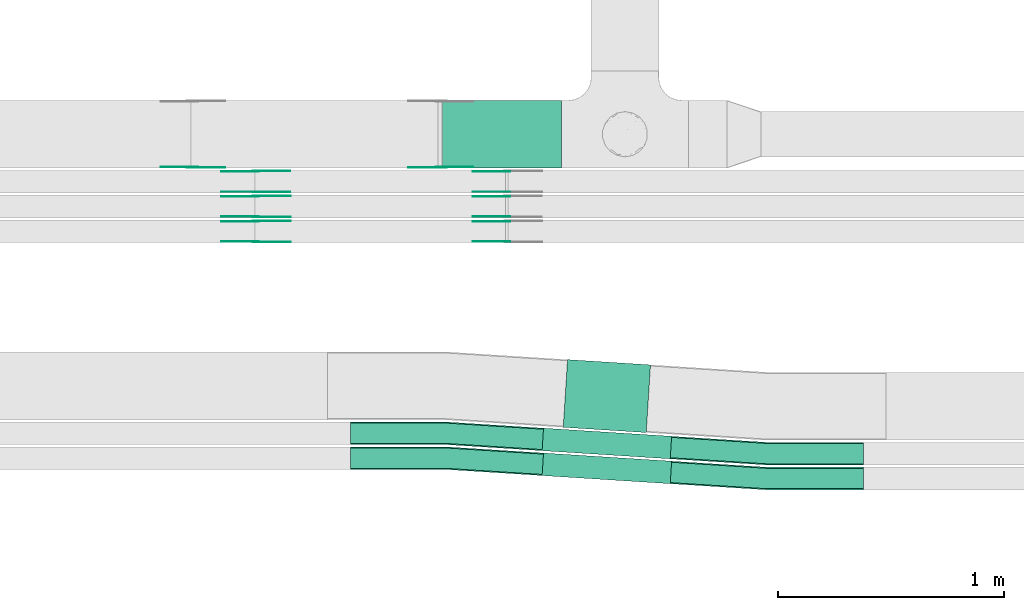
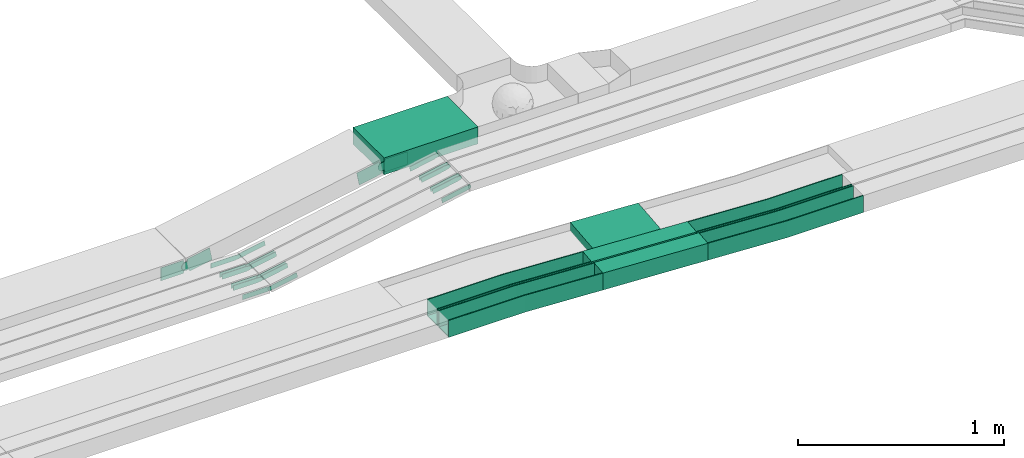
# One storey, part 11 of 33: 26 flow fittings, 4 flow segments.
"""IFC2X3 building model written with IfcOpenShell, lengths in millimetres."""

from ifc_helpers import new_model, entity, si_unit, converted_unit, derived_unit, direction, frame, frame_2d, origin, origin_2d_with_axis, place, context, subcontext, project, spatial, polyline, circle_curve, parameter, trimmed, segment, composite_curve, rectangle, outline, extrude, faceted_brep, source, transform, mapped, material, type_object, type_shapes, element, save


model = new_model("IFC2X3")

# Units and contexts
model_context = context("Model", 3, precision=0.01, world=origin(), true_north=direction((6.12303176911189e-17, 1.0)))
body_context = subcontext(model_context, "Body", "Model", "MODEL_VIEW")
ifc_project = project(units=[si_unit("LENGTHUNIT", "METRE", prefix="MILLI"), si_unit("AREAUNIT", "SQUARE_METRE"), si_unit("VOLUMEUNIT", "CUBIC_METRE"), converted_unit("PLANEANGLEUNIT", "DEGREE", entity("IfcRatioMeasure", 0.0174532925199433), si_unit("PLANEANGLEUNIT", "RADIAN"), dimensions=[0, 0, 0, 0, 0, 0, 0]), si_unit("MASSUNIT", "GRAM", prefix="KILO"), derived_unit("MASSDENSITYUNIT", [(si_unit("MASSUNIT", "GRAM", prefix="KILO"), 1), (si_unit("LENGTHUNIT", "METRE"), -3)]), derived_unit("MOMENTOFINERTIAUNIT", [(si_unit("LENGTHUNIT", "METRE"), 4)]), si_unit("TIMEUNIT", "SECOND"), si_unit("FREQUENCYUNIT", "HERTZ"), si_unit("THERMODYNAMICTEMPERATUREUNIT", "DEGREE_CELSIUS"), derived_unit("THERMALTRANSMITTANCEUNIT", [(si_unit("MASSUNIT", "GRAM", prefix="KILO"), 1), (si_unit("THERMODYNAMICTEMPERATUREUNIT", "KELVIN"), -1), (si_unit("TIMEUNIT", "SECOND"), -3)]), derived_unit("VOLUMETRICFLOWRATEUNIT", [(si_unit("LENGTHUNIT", "METRE"), 3), (si_unit("TIMEUNIT", "SECOND"), -1)]), derived_unit("MASSFLOWRATEUNIT", [(si_unit("MASSUNIT", "GRAM", prefix="KILO"), 1), (si_unit("TIMEUNIT", "SECOND"), -1)]), derived_unit("ROTATIONALFREQUENCYUNIT", [(si_unit("TIMEUNIT", "SECOND"), -1)]), si_unit("ELECTRICCURRENTUNIT", "AMPERE"), si_unit("ELECTRICVOLTAGEUNIT", "VOLT"), si_unit("POWERUNIT", "WATT"), si_unit("FORCEUNIT", "NEWTON", prefix="KILO"), si_unit("ILLUMINANCEUNIT", "LUX"), si_unit("LUMINOUSFLUXUNIT", "LUMEN"), si_unit("LUMINOUSINTENSITYUNIT", "CANDELA"), derived_unit("USERDEFINED", [(si_unit("MASSUNIT", "GRAM", prefix="KILO"), -1), (si_unit("LENGTHUNIT", "METRE"), -2), (si_unit("TIMEUNIT", "SECOND"), 3), (si_unit("LUMINOUSFLUXUNIT", "LUMEN"), 1)]), derived_unit("LINEARVELOCITYUNIT", [(si_unit("LENGTHUNIT", "METRE"), 1), (si_unit("TIMEUNIT", "SECOND"), -1)]), si_unit("PRESSUREUNIT", "PASCAL"), derived_unit("USERDEFINED", [(si_unit("LENGTHUNIT", "METRE"), -2), (si_unit("MASSUNIT", "GRAM", prefix="KILO"), 1), (si_unit("TIMEUNIT", "SECOND"), -2)]), derived_unit("LINEARFORCEUNIT", [(si_unit("MASSUNIT", "GRAM", prefix="KILO"), 1), (si_unit("LENGTHUNIT", "METRE"), 1), (si_unit("TIMEUNIT", "SECOND"), -2), (si_unit("LENGTHUNIT", "METRE"), -1)]), derived_unit("PLANARFORCEUNIT", [(si_unit("MASSUNIT", "GRAM", prefix="KILO"), 1), (si_unit("LENGTHUNIT", "METRE"), 1), (si_unit("TIMEUNIT", "SECOND"), -2), (si_unit("LENGTHUNIT", "METRE"), -2)])], contexts=[model_context])

# Site, building, storey
site_placement = place(None, frame((0.0, -0.00077364408347762, 0.0)))
site = spatial("IfcSite", under=ifc_project, at=site_placement, CompositionType="ELEMENT")
building_placement = place(site_placement, origin())
building = spatial("IfcBuilding", under=site, at=building_placement, CompositionType="ELEMENT")
storey_placement = place(building_placement, frame((0.0, 0.0, 8100.0)))
storey = spatial("IfcBuildingStorey", under=building, at=storey_placement, CompositionType="ELEMENT", Elevation=8100.0)

# Flow segments
cable_carrier_segment_type = type_object("IfcCableCarrierSegmentType", PredefinedType="CABLETRAYSEGMENT")
flow_segment_1_placement = place(storey_placement, frame((26284.4946938445, 9844.99855346683, 2800.0)))
element("IfcFlowSegment", 1, at=flow_segment_1_placement, inside=storey, type_object=cable_carrier_segment_type, context=body_context, shape_type="SweptSolid", body=[
    extrude(rectangle(XDim=526.511451475801, YDim=300.000000000001, at=origin_2d_with_axis()), frame((263.2557257379, 150.0, 0.0), z_axis=(0.0, 0.0, 1.0), x_axis=(-1.0, 0.0, 0.0)), (0.0, 0.0, 1.0), 99.9999999999989),
])
flow_segment_2_placement = place(storey_placement, frame((26724.5949227082, 8449.55820268328, 2789.31932519732)))
element("IfcFlowSegment", 2, at=flow_segment_2_placement, inside=storey, type_object=cable_carrier_segment_type, context=body_context, shape_type="SweptSolid", body=[
    extrude(rectangle(XDim=567.694436717267, YDim=100.000000000001, at=origin_2d_with_axis()), frame((286.44597921178, 67.893617861155, 0.0), z_axis=(0.0, 0.0, 1.0), x_axis=(-0.997988582354139, 0.0633939231375962, 0.0)), (0.0, 0.0, 1.0), 99.9999999999989),
])
flow_segment_3_placement = place(storey_placement, frame((26818.0543886301, 8675.69359732663, 2790.01530223368)))
element("IfcFlowSegment", 3, at=flow_segment_3_placement, inside=storey, type_object=cable_carrier_segment_type, context=body_context, shape_type="SweptSolid", body=[
    extrude(rectangle(XDim=367.694436689472, YDim=300.000000000001, at=frame_2d((4.2632564145606e-14, -5.40012479177676e-13), x_axis=(1.0, 0.0))), frame((192.986513276262, 161.353083781937, 0.0), z_axis=(0.0, 0.0, 1.0), x_axis=(0.997988582354136, -0.0633939231376403, 0.0)), (0.0, 0.0, 1.0), 50.0000000000016),
])
flow_segment_4_placement = place(storey_placement, frame((26724.594922708, 8559.55820268323, 2789.66918252178)))
element("IfcFlowSegment", 4, at=flow_segment_4_placement, inside=storey, type_object=cable_carrier_segment_type, context=body_context, shape_type="SweptSolid", body=[
    extrude(rectangle(XDim=567.694436717637, YDim=100.000000000001, at=frame_2d((2.18847162614111e-12, -4.01456645704457e-13), x_axis=(1.0, 0.0))), frame((286.445979211962, 67.8936178611777, 0.0), z_axis=(0.0, 0.0, 1.0), x_axis=(-0.997988582354137, 0.0633939231376368, 0.0)), (0.0, 0.0, 1.0), 99.9999999999989),
])

# Flow fittings
ifc_material_1 = material(Name="G")
cable_carrier_fitting_type_1 = type_object("IfcCableCarrierFittingType", PredefinedType="NOTDEFINED", material=ifc_material_1)
shared_shape_1 = source(origin(), body_context, "Body", "SweptSolid", [
    extrude(outline(composite_curve([segment(trimmed(circle_curve(frame_2d((-44.5901162790698, 0.0), x_axis=(1.0, 0.0)), 12.5), [parameter(90.0000000000007)], [parameter(270.0)], True, "PARAMETER"), True, "CONTINUOUS"), segment(polyline([(-44.5901162790697, -12.5), (-33.0901162790698, -12.5)]), True, "CONTINUOUS"), segment(polyline([(-33.0901162790698, -12.5), (-31.2296511627907, -14.5)]), True, "CONTINUOUS"), segment(polyline([(-31.2296511627907, -14.5), (108.90988372093, -14.5)]), True, "CONTINUOUS"), segment(polyline([(108.90988372093, -14.5), (108.90988372093, 14.5)]), True, "CONTINUOUS"), segment(polyline([(108.90988372093, 14.5), (-31.2296511627907, 14.5)]), True, "CONTINUOUS"), segment(polyline([(-31.2296511627907, 14.5), (-33.0901162790698, 12.5)]), True, "CONTINUOUS"), segment(polyline([(-33.0901162790698, 12.5), (-44.5901162790699, 12.5)]), True, "CONTINUOUS")], self_intersect=False)), frame((44.5901162790698, 0.0, 0.0), z_axis=(0.0, 0.0, -1.0), x_axis=(1.0, 0.0, 0.0)), (0.0, 0.0, -1.0), 2.0),
])
type_shapes(cable_carrier_fitting_type_1, [shared_shape_1])
for number, where, z_axis, x_axis in (
    (5, (25458.5258658325, 9520.01519660125, 2615.49251454767), (0.0, -1.0, 0.0), (0.982730588994864, 0.0, 0.185042128862072)),
    (6, (25458.5258658325, 9630.01519660127, 2615.43110636494), (0.0, -1.0, 0.0), (0.982701539841557, 0.0, 0.185196337957945)),
    (7, (25458.5258658325, 9739.53855345657, 2614.15529134034), (0.0, -1.0, 0.0), (0.982500640063244, 0.0, 0.186259207222932)),
):
    element("IfcFlowFitting", number, at=place(storey_placement, frame(where, z_axis=z_axis, x_axis=x_axis)), inside=storey, type_object=cable_carrier_fitting_type_1, material=ifc_material_1, context=body_context, shape_type="MappedRepresentation", body=[
        mapped(shared_shape_1, transform((0.0, 0.0, 0.0), scale=1.0)),
    ])
cable_carrier_fitting_type_2 = type_object("IfcCableCarrierFittingType", PredefinedType="NOTDEFINED", material=ifc_material_1)
shared_shape_2 = source(origin(), body_context, "Body", "SweptSolid", [
    extrude(outline(composite_curve([segment(trimmed(circle_curve(frame_2d((-44.5901162790697, 0.0), x_axis=(1.0, 0.0)), 12.5), [parameter(90.0000000000007)], [parameter(270.0)], True, "PARAMETER"), True, "CONTINUOUS"), segment(polyline([(-44.5901162790697, -12.5), (-33.0901162790697, -12.5)]), True, "CONTINUOUS"), segment(polyline([(-33.0901162790697, -12.5), (-31.2296511627907, -14.5)]), True, "CONTINUOUS"), segment(polyline([(-31.2296511627907, -14.5), (108.90988372093, -14.5)]), True, "CONTINUOUS"), segment(polyline([(108.90988372093, -14.5), (108.90988372093, 14.5)]), True, "CONTINUOUS"), segment(polyline([(108.90988372093, 14.5), (-31.2296511627907, 14.5)]), True, "CONTINUOUS"), segment(polyline([(-31.2296511627907, 14.5), (-33.0901162790698, 12.5)]), True, "CONTINUOUS"), segment(polyline([(-33.0901162790698, 12.5), (-44.5901162790699, 12.5)]), True, "CONTINUOUS")], self_intersect=False)), frame((44.5901162790697, 0.0, 0.0)), (0.0, 0.0, 1.0), 2.0),
])
type_shapes(cable_carrier_fitting_type_2, [shared_shape_2])
for number, where, z_axis, x_axis in (
    (8, (25458.5258658325, 9610.93519662157, 2615.49251454767), (0.0, 1.0, 0.0), (0.982730588994864, 0.0, 0.185042128862072)),
    (9, (25458.5258658325, 9720.93519662159, 2615.43110636494), (0.0, 1.0, 0.0), (0.982701539841557, 0.0, 0.185196337957945)),
    (10, (25458.5258658325, 9830.45855347688, 2614.15529134034), (0.0, 1.0, 0.0), (0.982500640063244, 0.0, 0.186259207222932)),
):
    element("IfcFlowFitting", number, at=place(storey_placement, frame(where, z_axis=z_axis, x_axis=x_axis)), inside=storey, type_object=cable_carrier_fitting_type_2, material=ifc_material_1, context=body_context, shape_type="MappedRepresentation", body=[
        mapped(shared_shape_2, transform((0.0, 0.0, 0.0), scale=1.0)),
    ])
cable_carrier_fitting_type_3 = type_object("IfcCableCarrierFittingType", PredefinedType="NOTDEFINED", material=ifc_material_1)
shared_shape_3 = source(origin(), body_context, "Body", "SweptSolid", [
    extrude(outline(composite_curve([segment(trimmed(circle_curve(frame_2d((-44.5901162790698, 0.0), x_axis=(1.0, 0.0)), 12.5), [parameter(90.0000000000007)], [parameter(270.0)], True, "PARAMETER"), True, "CONTINUOUS"), segment(polyline([(-44.5901162790697, -12.5), (-33.0901162790698, -12.5)]), True, "CONTINUOUS"), segment(polyline([(-33.0901162790698, -12.5), (-31.2296511627907, -14.5)]), True, "CONTINUOUS"), segment(polyline([(-31.2296511627907, -14.5), (108.90988372093, -14.5)]), True, "CONTINUOUS"), segment(polyline([(108.90988372093, -14.5), (108.90988372093, 14.5)]), True, "CONTINUOUS"), segment(polyline([(108.90988372093, 14.5), (-31.2296511627907, 14.5)]), True, "CONTINUOUS"), segment(polyline([(-31.2296511627907, 14.5), (-33.0901162790698, 12.5)]), True, "CONTINUOUS"), segment(polyline([(-33.0901162790698, 12.5), (-44.5901162790699, 12.5)]), True, "CONTINUOUS")], self_intersect=False)), frame((44.5901162790698, 0.0, 0.0), z_axis=(0.0, 0.0, -1.0), x_axis=(1.0, 0.0, 0.0)), (0.0, 0.0, -1.0), 2.0),
])
type_shapes(cable_carrier_fitting_type_3, [shared_shape_3])
for number, where, z_axis, x_axis in (
    (11, (25458.5258658325, 9608.93519662157, 2615.49251454767), (0.0, 1.0, 0.0), (-1.0, 0.0, 0.0)),
    (12, (25458.5258658325, 9718.93519662159, 2615.43110636495), (0.0, 1.0, 0.0), (-1.0, 0.0, 0.0)),
    (13, (25458.5258658325, 9828.45855347689, 2614.15529134034), (0.0, 1.0, 0.0), (-1.0, 0.0, 0.0)),
    (14, (26571.188240847, 9522.01519660125, 2825.0), (0.0, -1.0, 0.0), (-0.982730588994865, 0.0, -0.185042128862065)),
    (15, (26570.5547361058, 9632.01519660129, 2825.0), (0.0, -1.0, 0.0), (-0.982701539841558, 0.0, -0.185196337957939)),
    (16, (26570.7128245376, 9741.53855345658, 2825.0), (0.0, -1.0, 0.0), (-0.982500640063246, 0.0, -0.186259207222926)),
):
    element("IfcFlowFitting", number, at=place(storey_placement, frame(where, z_axis=z_axis, x_axis=x_axis)), inside=storey, type_object=cable_carrier_fitting_type_3, material=ifc_material_1, context=body_context, shape_type="MappedRepresentation", body=[
        mapped(shared_shape_3, transform((0.0, 0.0, 0.0), scale=1.0)),
    ])
cable_carrier_fitting_type_4 = type_object("IfcCableCarrierFittingType", PredefinedType="NOTDEFINED", material=ifc_material_1)
shared_shape_4 = source(origin(), body_context, "Body", "SweptSolid", [
    extrude(outline(composite_curve([segment(trimmed(circle_curve(frame_2d((-44.5901162790697, 0.0), x_axis=(1.0, 0.0)), 12.5), [parameter(90.0000000000007)], [parameter(270.0)], True, "PARAMETER"), True, "CONTINUOUS"), segment(polyline([(-44.5901162790697, -12.5), (-33.0901162790697, -12.5)]), True, "CONTINUOUS"), segment(polyline([(-33.0901162790697, -12.5), (-31.2296511627907, -14.5)]), True, "CONTINUOUS"), segment(polyline([(-31.2296511627907, -14.5), (108.90988372093, -14.5)]), True, "CONTINUOUS"), segment(polyline([(108.90988372093, -14.5), (108.90988372093, 14.5)]), True, "CONTINUOUS"), segment(polyline([(108.90988372093, 14.5), (-31.2296511627907, 14.5)]), True, "CONTINUOUS"), segment(polyline([(-31.2296511627907, 14.5), (-33.0901162790698, 12.5)]), True, "CONTINUOUS"), segment(polyline([(-33.0901162790698, 12.5), (-44.5901162790699, 12.5)]), True, "CONTINUOUS")], self_intersect=False)), frame((44.5901162790697, 0.0, 0.0)), (0.0, 0.0, 1.0), 2.0),
])
type_shapes(cable_carrier_fitting_type_4, [shared_shape_4])
for number, where, z_axis, x_axis in (
    (17, (25458.5258658325, 9522.01519660125, 2615.49251454768), (0.0, -1.0, 0.0), (-1.0, 0.0, 0.0)),
    (18, (25458.5258658325, 9632.01519660128, 2615.43110636495), (0.0, -1.0, 0.0), (-1.0, 0.0, 0.0)),
    (19, (25458.5258658325, 9741.53855345657, 2614.15529134035), (0.0, -1.0, 0.0), (-1.0, 0.0, 0.0)),
    (20, (26571.188240847, 9608.93519662157, 2825.0), (0.0, 1.0, 0.0), (-0.982730588994865, 0.0, -0.185042128862065)),
    (21, (26570.5547361058, 9718.9351966216, 2825.0), (0.0, 1.0, 0.0), (-0.982701539841558, 0.0, -0.185196337957939)),
    (22, (26570.7128245376, 9828.45855347689, 2825.0), (0.0, 1.0, 0.0), (-0.982500640063246, 0.0, -0.186259207222926)),
):
    element("IfcFlowFitting", number, at=place(storey_placement, frame(where, z_axis=z_axis, x_axis=x_axis)), inside=storey, type_object=cable_carrier_fitting_type_4, material=ifc_material_1, context=body_context, shape_type="MappedRepresentation", body=[
        mapped(shared_shape_4, transform((0.0, 0.0, 0.0), scale=1.0)),
    ])
cable_carrier_fitting_type_5 = type_object("IfcCableCarrierFittingType", PredefinedType="NOTDEFINED", material=ifc_material_1)
shared_shape_5 = source(origin(), body_context, "Body", "SweptSolid", [
    extrude(outline(composite_curve([segment(trimmed(circle_curve(frame_2d((-41.4651162790697, 0.0), x_axis=(1.0, 0.0)), 25.0), [parameter(90.0000000000007)], [parameter(270.0)], True, "PARAMETER"), True, "CONTINUOUS"), segment(polyline([(-41.4651162790697, -25.0), (-29.9651162790697, -25.0)]), True, "CONTINUOUS"), segment(polyline([(-29.9651162790697, -25.0), (-28.1046511627907, -38.5)]), True, "CONTINUOUS"), segment(polyline([(-28.1046511627907, -38.5), (99.5348837209303, -38.5)]), True, "CONTINUOUS"), segment(polyline([(99.5348837209303, -38.5), (99.5348837209303, 38.5)]), True, "CONTINUOUS"), segment(polyline([(99.5348837209303, 38.5), (-28.1046511627907, 38.5)]), True, "CONTINUOUS"), segment(polyline([(-28.1046511627907, 38.5), (-29.9651162790697, 25.0)]), True, "CONTINUOUS"), segment(polyline([(-29.9651162790697, 25.0), (-41.46511627907, 25.0)]), True, "CONTINUOUS")], self_intersect=False)), frame((41.4651162790697, 0.0, 0.0), z_axis=(0.0, 0.0, -1.0), x_axis=(1.0, 0.0, 0.0)), (0.0, 0.0, -1.0), 2.0),
])
type_shapes(cable_carrier_fitting_type_5, [shared_shape_5])
for number, where, z_axis, x_axis in (
    (23, (25178.5258658326, 9849.53855345668, 2645.01712441877), (0.0, -1.0, 0.0), (0.983076107251628, 0.0, 0.183197618300528)),
    (24, (26278.5061453203, 9849.53855345667, 2850.0), (0.0, -1.0, 0.0), (-0.983076107251628, 0.0, -0.183197618300528)),
):
    element("IfcFlowFitting", number, at=place(storey_placement, frame(where, z_axis=z_axis, x_axis=x_axis)), inside=storey, type_object=cable_carrier_fitting_type_5, material=ifc_material_1, context=body_context, shape_type="MappedRepresentation", body=[
        mapped(shared_shape_5, transform((0.0, 0.0, 0.0), scale=1.0)),
    ])
cable_carrier_fitting_type_6 = type_object("IfcCableCarrierFittingType", PredefinedType="NOTDEFINED", material=ifc_material_1)
shared_shape_6 = source(origin(), body_context, "Body", "SweptSolid", [
    extrude(outline(composite_curve([segment(trimmed(circle_curve(frame_2d((-41.4651162790697, 0.0), x_axis=(1.0, 0.0)), 25.0), [parameter(90.0000000000007)], [parameter(270.0)], True, "PARAMETER"), True, "CONTINUOUS"), segment(polyline([(-41.4651162790697, -25.0), (-29.9651162790697, -25.0)]), True, "CONTINUOUS"), segment(polyline([(-29.9651162790697, -25.0), (-28.1046511627907, -38.5)]), True, "CONTINUOUS"), segment(polyline([(-28.1046511627907, -38.5), (99.5348837209303, -38.5)]), True, "CONTINUOUS"), segment(polyline([(99.5348837209303, -38.5), (99.5348837209303, 38.5)]), True, "CONTINUOUS"), segment(polyline([(99.5348837209303, 38.5), (-28.1046511627907, 38.5)]), True, "CONTINUOUS"), segment(polyline([(-28.1046511627907, 38.5), (-29.9651162790697, 25.0)]), True, "CONTINUOUS"), segment(polyline([(-29.9651162790697, 25.0), (-41.46511627907, 25.0)]), True, "CONTINUOUS")], self_intersect=False)), frame((41.4651162790697, 0.0, 0.0)), (0.0, 0.0, 1.0), 2.0),
])
type_shapes(cable_carrier_fitting_type_6, [shared_shape_6])
for number, where, z_axis, x_axis in (
    (25, (25178.5258658326, 9851.53855345668, 2645.01712441878), (0.0, -1.0, 0.0), (-1.0, 0.0, 0.0)),
    (26, (26278.5061453203, 9851.53855345668, 2850.0), (0.0, -1.0, 0.0), (1.0, 0.0, 0.0)),
):
    element("IfcFlowFitting", number, at=place(storey_placement, frame(where, z_axis=z_axis, x_axis=x_axis)), inside=storey, type_object=cable_carrier_fitting_type_6, material=ifc_material_1, context=body_context, shape_type="MappedRepresentation", body=[
        mapped(shared_shape_6, transform((0.0, 0.0, 0.0), scale=1.0)),
    ])
ifc_material_2 = material()
cable_carrier_fitting_type_7 = type_object("IfcCableCarrierFittingType", Name="470_DKC_G5_Sheet horizontal bend:-", PredefinedType="NOTDEFINED", material=ifc_material_2)
shared_shape_7 = source(origin(), body_context, "Body", "Brep", [
    faceted_brep([(-426.0, -50.0, -50.0), (-426.0, -50.0, 50.0), (-426.0, -45.0, 50.0), (-426.0, -45.0, -45.0), (-426.0, 45.0, -45.0), (-426.0, 45.0, 50.0), (-426.0, 50.0, 50.0), (-426.0, 50.0, -50.0), (1.58644357875045, -50.0, -50.0), (1.58644357875045, -50.0, 50.0), (428.312832239749, -22.893617861102, 50.0), (427.995862624062, -17.9036749493311, 50.0), (1.42779922087602, -45.0, 50.0), (1.42779922087602, -45.0, -45.0), (427.995862624061, -17.9036749493311, -45.0), (422.290409541678, 71.9152974625413, -45.0), (-1.42779922086357, 45.0, -45.0), (-1.42779922086357, 45.0, 50.0), (422.290409541678, 71.9152974625413, 50.0), (421.97343992599, 76.9052403743119, 50.0), (-1.58644357873793, 50.0, 50.0), (-1.58644357873793, 50.0, -50.0), (421.97343992599, 76.9052403743119, -50.0), (428.31283223975, -22.893617861102, -50.0)], [[[0, 1, 2, 3, 4, 5, 6, 7]], [[1, 0, 8, 9]], [[2, 1, 9, 10, 11, 12]], [[3, 2, 12, 13]], [[4, 3, 13, 14, 15, 16]], [[5, 4, 16, 17]], [[6, 5, 17, 18, 19, 20]], [[7, 6, 20, 21]], [[8, 0, 7, 21, 22, 23]], [[23, 22, 19, 18, 15, 14, 11, 10]], [[9, 8, 23, 10]], [[13, 12, 11, 14]], [[17, 16, 15, 18]], [[21, 20, 19, 22]]]),
])
type_shapes(cable_carrier_fitting_type_7, [shared_shape_7])
for number, where, z_axis, x_axis, name in (
    (27, (27719.4603210579, 8582.45182054433, 2839.66918252179), (0.0, 0.0, 1.0), (0.997988582354139, -0.0633939231376085, 0.0), "470_DKC_G5_Sheet horizontal bend:-"),
    (28, (27719.4603210577, 8472.45182054441, 2839.31932519733), (0.0, 0.0, 1.0), (0.997988582354141, -0.0633939231375666, 0.0), "470_DKC_G5_Sheet horizontal bend:-"),
    (29, (26302.6214827823, 8562.45182054448, 2839.31932519732), (0.0, 0.0, 1.0), (-0.997988582354139, 0.0633939231375962, 0.0), "470_DKC_G5_Sheet horizontal bend:-"),
    (30, (26302.6214827819, 8672.45182054451, 2839.66918252178), (0.0, 0.0, 1.0), (-0.997988582354137, 0.0633939231376368, 0.0), "470_DKC_G5_Sheet horizontal bend:-"),
):
    element("IfcFlowFitting", number, at=place(storey_placement, frame(where, z_axis=z_axis, x_axis=x_axis)), inside=storey, type_object=cable_carrier_fitting_type_7, material=ifc_material_2, Name=name, ObjectType="470_DKC_G5_Sheet horizontal bend:-", context=body_context, shape_type="MappedRepresentation", body=[
        mapped(shared_shape_7, transform((0.0, 0.0, 0.0), scale=1.0)),
    ])

save(model, "model.ifc")
